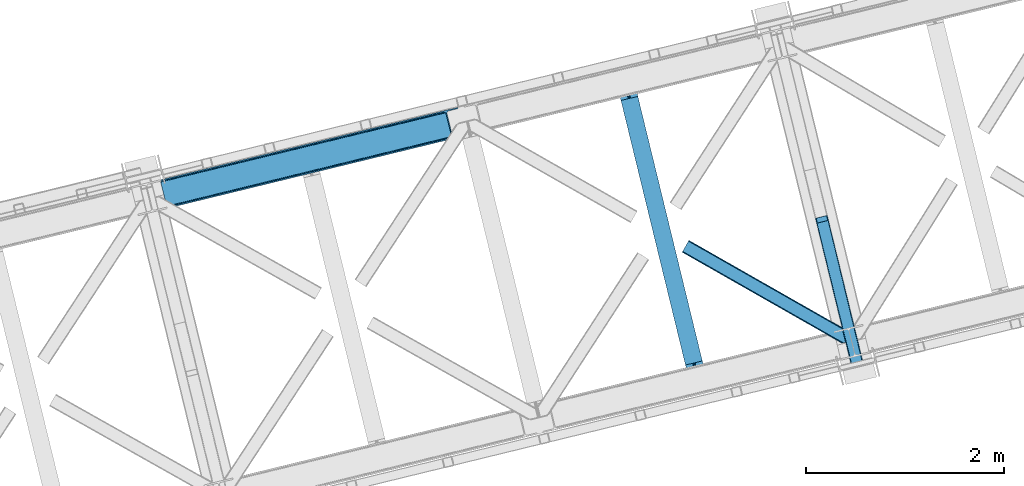
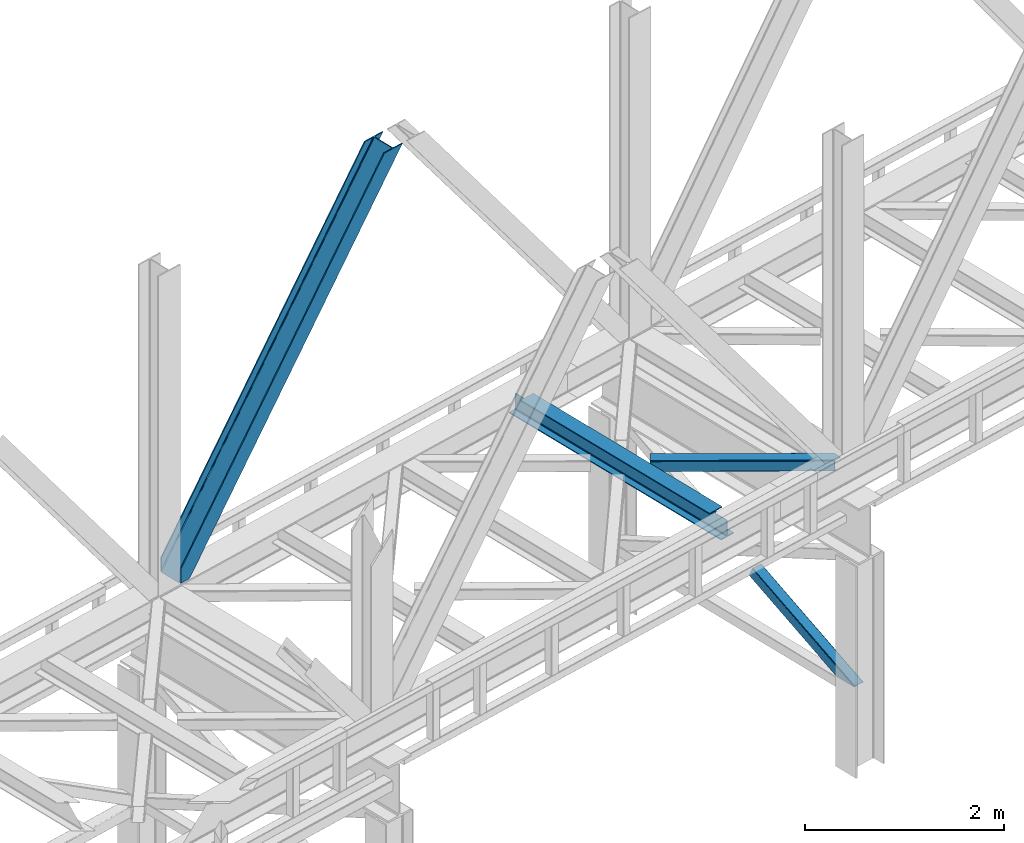
# One storey, part 55 of 92: 3 members, 1 beam.
"""IFC4 building model written with IfcOpenShell, lengths in millimetres."""

from ifc_helpers import new_model, entity, si_unit, converted_unit, derived_unit, direction, frame, origin, place, context, subcontext, project, spatial, triangles, polygons, material, type_object, element, save


model = new_model("IFC4")

# Units and contexts
model_context = context("Model", 3, precision=0.01, world=origin(), true_north=direction((6.12303176911189e-17, 1.0)))
plan_context = context("Plan", 3, precision=0.01, world=origin(), true_north=direction((6.12303176911189e-17, 1.0)))
body_context = subcontext(model_context, "Body", "Model", "MODEL_VIEW")
ifc_project = project(units=[si_unit("LENGTHUNIT", "METRE", prefix="MILLI"), si_unit("AREAUNIT", "SQUARE_METRE"), si_unit("VOLUMEUNIT", "CUBIC_METRE"), converted_unit("PLANEANGLEUNIT", "DEGREE", entity("IfcRatioMeasure", 0.0174532925199433), si_unit("PLANEANGLEUNIT", "RADIAN"), dimensions=[0, 0, 0, 0, 0, 0, 0]), si_unit("MASSUNIT", "GRAM", prefix="KILO"), derived_unit("MASSDENSITYUNIT", [(si_unit("MASSUNIT", "GRAM", prefix="KILO"), 1), (si_unit("LENGTHUNIT", "METRE"), -3)]), derived_unit("MOMENTOFINERTIAUNIT", [(si_unit("LENGTHUNIT", "METRE"), 4)]), si_unit("TIMEUNIT", "SECOND"), si_unit("FREQUENCYUNIT", "HERTZ"), si_unit("THERMODYNAMICTEMPERATUREUNIT", "DEGREE_CELSIUS"), derived_unit("THERMALTRANSMITTANCEUNIT", [(si_unit("MASSUNIT", "GRAM", prefix="KILO"), 1), (si_unit("THERMODYNAMICTEMPERATUREUNIT", "KELVIN"), -1), (si_unit("TIMEUNIT", "SECOND"), -3)]), derived_unit("VOLUMETRICFLOWRATEUNIT", [(si_unit("LENGTHUNIT", "METRE"), 3), (si_unit("TIMEUNIT", "SECOND"), -1)]), derived_unit("MASSFLOWRATEUNIT", [(si_unit("MASSUNIT", "GRAM", prefix="KILO"), 1), (si_unit("TIMEUNIT", "SECOND"), -1)]), derived_unit("ROTATIONALFREQUENCYUNIT", [(si_unit("TIMEUNIT", "SECOND"), -1)]), si_unit("ELECTRICCURRENTUNIT", "AMPERE"), si_unit("ELECTRICVOLTAGEUNIT", "VOLT"), si_unit("POWERUNIT", "WATT"), si_unit("FORCEUNIT", "NEWTON", prefix="KILO"), si_unit("ILLUMINANCEUNIT", "LUX"), si_unit("LUMINOUSFLUXUNIT", "LUMEN"), si_unit("LUMINOUSINTENSITYUNIT", "CANDELA"), derived_unit("USERDEFINED", [(si_unit("MASSUNIT", "GRAM", prefix="KILO"), -1), (si_unit("LENGTHUNIT", "METRE"), -2), (si_unit("TIMEUNIT", "SECOND"), 3), (si_unit("LUMINOUSFLUXUNIT", "LUMEN"), 1)]), derived_unit("LINEARVELOCITYUNIT", [(si_unit("LENGTHUNIT", "METRE"), 1), (si_unit("TIMEUNIT", "SECOND"), -1)]), si_unit("PRESSUREUNIT", "PASCAL"), derived_unit("USERDEFINED", [(si_unit("LENGTHUNIT", "METRE"), -2), (si_unit("MASSUNIT", "GRAM", prefix="KILO"), 1), (si_unit("TIMEUNIT", "SECOND"), -2)]), derived_unit("LINEARFORCEUNIT", [(si_unit("MASSUNIT", "GRAM", prefix="KILO"), 1), (si_unit("LENGTHUNIT", "METRE"), 1), (si_unit("TIMEUNIT", "SECOND"), -2), (si_unit("LENGTHUNIT", "METRE"), -1)]), derived_unit("PLANARFORCEUNIT", [(si_unit("MASSUNIT", "GRAM", prefix="KILO"), 1), (si_unit("LENGTHUNIT", "METRE"), 1), (si_unit("TIMEUNIT", "SECOND"), -2), (si_unit("LENGTHUNIT", "METRE"), -2)])], contexts=[model_context, plan_context])

# Site, building, storey
site_placement = place(None, origin())
site = spatial("IfcSite", under=ifc_project, at=site_placement, CompositionType="ELEMENT")
building_placement = place(site_placement, origin())
building = spatial("IfcBuilding", under=site, at=building_placement, CompositionType="ELEMENT")
storey_placement = place(building_placement, frame((0.0, 0.0, 15900.0)))
storey = spatial("IfcBuildingStorey", under=building, at=storey_placement, Name="05", CompositionType="ELEMENT", Elevation=15900.0)

# Beam
ifc_material = material(Name="Metal painted (White)")
beam_type = type_object("IfcBeamType", PredefinedType="BEAM")
beam_placement = place(storey_placement, frame((-31800.92, 10034.89, 3441.0)))
element("IfcBeam", 1, at=beam_placement, inside=storey, type_object=beam_type, material=ifc_material, ObjectType="Steel Beam", PredefinedType="BEAM", context=body_context, shape_type="Tessellation", body=[
    polygons([(900.98534618944, 41.4445662733081, 11.000000000004), (900.98534618944, 41.4445662733081, 2.16573425859679e-12), (170.021610174761, 3040.13999372697, 2.16573425859679e-12), (170.021610174761, 3040.13999372697, 11.000000000004), (834.919806235814, 25.3403919499634, 11.000000000004), (103.956070221139, 3024.03581940362, 11.000000000004), (828.971056214522, 23.8903211957374, 12.2179274798217), (98.007320199847, 3022.5857486494, 12.2179274798217), (823.927949458418, 22.6610105689194, 15.6862915010192), (92.9642134437384, 3021.35643802258, 15.6862915010192), (820.558253255246, 21.8396114687119, 20.8770650821657), (89.5945172405668, 3020.53503892237, 20.8770650821657), (819.374973305552, 21.5511744621184, 27.0000000000047), (88.4112372908766, 3020.24660191578, 27.0000000000047), (81.6103728838888, 3018.58881926485, 27.0000000000047), (81.6103728838844, 3018.58881926485, 203.000000000006), (88.4112372908766, 3020.24660191578, 203.000000000006), (0.0, 2998.69542745366, 2.16573425859679e-12), (4.33146851719357e-12, 2998.69542745366, 10.9999999999997), (66.0655399536259, 3014.799601777, 11.000000000004), (72.0142899749184, 3016.24967253123, 12.2179274798217), (77.0573967310183, 3017.47898315805, 15.6862915010192), (80.4270929342029, 3018.30038225825, 20.8770650821613), (819.374973305556, 21.5511744621184, 203.000000000006), (812.574108898559, 19.8933918111876, 203.000000000006), (812.574108898568, 19.8933918111876, 27.0000000000047), (811.390828948882, 19.6049548045963, 20.8770650821613), (808.021132745698, 18.7835557043866, 15.6862915010192), (802.978025989598, 17.5542450775685, 12.2179274798217), (797.029275968305, 16.1041743233403, 11.000000000004), (730.963736014684, -2.16573425859679e-12, 10.9999999999997), (730.963736014679, -2.16573425859679e-12, 2.16573425859679e-12), (779.675212882766, 184.415062601692, 203.069791966819), (128.020401343517, 2857.75452019162, 203.000000000006), (128.243282132667, 2856.84017775719, 203.617301946336), (128.25619637719, 2856.7871977843, 217.000003693143), (779.530009633841, 185.010597404072, 217.000003676718), (779.530880241731, 185.007025963192, 204.00000679514), (772.96491171832, 182.385463974439, 203.006342981529), (772.742064056778, 183.299815969774, 203.617301946336), (772.729149812254, 183.352795942665, 217.000003693143), (121.455336555608, 2855.12939632289, 217.000003676718), (121.45446594771, 2855.13296776377, 204.00000679514), (121.31016635866, 2855.72494066435, 203.076120467494), (121.219536936524, 2856.09673754069, 203.000000000006), (780.713494357868, 185.298194377514, 223.122939328039), (784.082490766543, 186.122464201391, 228.313710402595), (789.125126170563, 187.353708426697, 231.782072735464), (795.073705041266, 188.804481281379, 232.999999602236), (861.13915590679, 204.909021065313, 232.999999283132), (861.137682570352, 204.915065042186, 243.999994005812), (691.116301666435, 163.469558245295, 243.999994827032), (691.117775002873, 163.463514268422, 233.000000104353), (757.183225868396, 179.568054052358, 232.999999785253), (763.132130996735, 181.017488520584, 231.782072861012), (768.175695503857, 182.244921343716, 228.313710479427), (771.546082413602, 183.063487001146, 223.12293937232), (120.271851831572, 2854.84179934945, 223.122939328039), (116.902855422893, 2854.01752952557, 228.313710402595), (111.860220018882, 2852.78628530027, 231.782072735464), (105.91164114817, 2851.33551244559, 232.999999602236), (39.8461902826462, 2835.23097266165, 232.999999283128), (39.8476636190837, 2835.22492868478, 243.999994005812), (209.869044523001, 2876.67043548167, 243.999994827032), (209.867571186563, 2876.67647945854, 233.000000104357), (143.802120321035, 2860.57193967461, 232.999999785253), (137.853215192714, 2859.12250520638, 231.782072861012), (132.809650685579, 2857.89507238325, 228.313710479427), (129.439263775843, 2857.07650672582, 223.12293937232)], [[[1, 2, 3, 4]], [[5, 1, 4, 6]], [[7, 5, 6, 8]], [[9, 7, 8, 10]], [[11, 9, 10, 12]], [[13, 11, 12, 14]], [[15, 16, 17, 14, 12, 10, 8, 6, 4, 3, 18, 19, 20, 21, 22, 23]], [[13, 24, 25, 26, 27, 28, 29, 30, 31, 32, 2, 1, 5, 7, 9, 11]], [[2, 32, 18, 3]], [[32, 31, 19, 18]], [[31, 30, 20, 19]], [[27, 26, 15, 23]], [[28, 27, 23, 22]], [[29, 28, 22, 21]], [[30, 29, 21, 20]], [[33, 24, 13, 14, 17, 34, 35, 36, 37, 38]], [[25, 39, 40, 41, 42, 43, 44, 16, 15, 26]], [[39, 25, 24, 33]], [[45, 34, 17, 16]], [[41, 40, 38, 37, 46, 47, 48, 49, 50, 51, 52, 53, 54, 55, 56, 57]], [[42, 58, 59, 60, 61, 62, 63, 64, 65, 66, 67, 68, 69, 36, 35, 43]], [[46, 37, 36, 69]], [[47, 46, 69, 68]], [[48, 47, 68, 67]], [[49, 48, 67, 66]], [[50, 49, 66, 65]], [[51, 50, 65, 64]], [[52, 51, 64, 63]], [[53, 52, 63, 62]], [[54, 53, 62, 61]], [[55, 54, 61, 60]], [[56, 55, 60, 59]], [[57, 56, 59, 58]], [[41, 57, 58, 42]]], closed=False),
])

# Members
member_type_1 = type_object("IfcMemberType", PredefinedType="BRACE")
member_1_placement = place(storey_placement, frame((-36411.18, 11783.17, 3695.0)))
element("IfcMember", 2, at=member_1_placement, inside=storey, type_object=member_type_1, ObjectType="Steel Vertical Brace", PredefinedType="BRACE", context=body_context, shape_type="Tessellation", body=[
    triangles([(58.5289855957017, 27.9227142333984, 0.0), (60.4544494628863, 20.0173828124989, 0.0), (59.0963928222627, 20.9719757080074, 0.827856445310317), (58.9708190917954, 19.7941406249993, 1.13481445312209), (72.0351379394488, 11.6585906982418, 0.0), (71.2235595703096, 13.9003143310547, 30.2981506347642), (70.0794433593765, 15.4013854980458, 25.0194030761704), (72.0351379394488, 11.6585906982418, 170.803527832031), (71.7537597656265, 12.6201599121086, 41.9881347656228), (71.7537597656265, 12.6201599121086, 170.743066406249), (70.2445495605425, 15.5234710693348, 0.0), (68.6423217773408, 17.2884796142571, 18.377947998044), (66.9517272949233, 18.0907562255852, 14.9735046386704), (67.1168334960894, 18.4186431884755, 0.0), (63.12870483398, 19.9092498779282, 7.26932373046657), (63.12870483398, 19.9092498779282, 0.0), (2824.67177124023, 683.673385620117, 3911.00081176758), (2919.44040527344, 706.773138427734, 3911.00081176758), (2937.07653808594, 722.50938720703, 3911.00081176758), (2933.70465087891, 715.67724609375, 3911.00081176758), (2937.11839599609, 729.608953857422, 3911.00081176758), (2927.51200561523, 710.150839233398, 3911.00081176758), (2827.75065307617, 671.042761230468, 3911.00081176758), (74.8768249511704, 0.0, 170.803527832031), (74.8768249511704, 0.0, 0.0), (192.937060546872, 28.7784759521473, 0.0), (3071.52647094726, 730.46471557617, 3911.00081176758), (3068.44758911133, 743.095339965819, 3911.00081176758), (189.858178710936, 41.4091003417961, 0.0), (2973.67895507813, 719.994424438475, 3911.00081176758), (95.0918701171831, 18.308184814452, 0.0), (2964.95855712891, 719.279351806639, 3911.00081176758), (86.3691467285171, 17.5931121826161, 0.0), (2956.9171875, 721.336203002929, 3911.00081176758), (78.3277770996065, 19.648800659179, 0.0), (2950.77802734375, 725.848718261717, 3911.00081176758), (72.190942382811, 24.1624786376942, 0.0), (2947.47590332031, 732.134381103515, 3911.00081176758), (68.8888183593735, 30.4481414794918, 0.0), (2892.29555053711, 958.506610107421, 3911.00081176758), (13.7084655761719, 256.820370483398, 0.0), (2892.33508300781, 965.606176757812, 3911.00081176758), (13.7456726074233, 263.919937133789, 0.0), (2895.7092956543, 972.438317871092, 3911.00081176758), (17.1198852539019, 270.752078247069, 0.0), (2901.90194091797, 977.964724731444, 3911.00081176758), (23.3125305175781, 276.277322387694, 0.0), (2909.97354125977, 981.342425537108, 3911.00081176758), (31.3864562988238, 279.656185913085, 0.0), (3004.73984985351, 1004.44334106445, 3911.00081176758), (126.150439453122, 302.755938720702, 0.0), (3001.66096801758, 1017.07280273437, 3911.00081176758), (123.071557617186, 315.386563110351, 0.0), (2881.93804321289, 955.981182861327, 3911.00081176758), (3.34630737304542, 254.294943237304, 0.0), (2872.49443359375, 966.78052368164, 3911.00081176758), (2864.45306396484, 968.836212158203, 3911.00081176758), (2757.88747558594, 957.650848388672, 3911.00081176758), (2855.73499145508, 968.121139526367, 3911.00081176758), (2760.96635742187, 945.020223999023, 3911.00081176758), (2878.63359375, 962.265682983398, 3911.00081176758), (5.01364746093896, 286.608087158202, 170.803527832031), (5.01364746093896, 286.608087158202, 0.0), (7.85533447265334, 274.94949645996, 170.803527832031), (8.0460205078125, 273.966998291015, 170.743066406249), (8.0460205078125, 273.966998291015, 41.9881347656228), (7.85533447265334, 274.94949645996, 0.0), (3.74395751953125, 263.525775146483, 0.0), (6.59959716796584, 266.686047363281, 0.0), (8.04369506835792, 270.693942260741, 0.0), (1.42084350586083, 262.199111938477, 0.0), (3.74395751953125, 263.525775146483, 7.26932373046657), (6.30194091796875, 266.898825073242, 14.9735046386704), (7.43442993163626, 268.391757202147, 18.377947998044), (8.16694335937063, 272.585687255858, 30.2981506347642), (7.84138183593313, 270.727661132813, 25.0194030761704), (0.0, 261.715420532226, 1.13481445312209), (0.65344848632958, 260.728271484375, 0.827856445310317)], [[1, 2, 3], [4, 3, 2], [5, 6, 7], [5, 8, 9], [10, 9, 8], [9, 6, 5], [11, 12, 13], [11, 7, 12], [14, 13, 15], [15, 4, 2], [2, 16, 15], [15, 16, 14], [13, 14, 11], [7, 11, 5], [17, 18, 10], [9, 10, 18], [19, 3, 15], [15, 20, 19], [12, 20, 13], [15, 13, 20], [3, 4, 15], [19, 21, 1], [1, 3, 19], [6, 20, 7], [6, 22, 20], [12, 7, 20], [18, 22, 9], [6, 9, 22], [8, 17, 10], [23, 8, 24], [8, 23, 17], [25, 24, 5], [8, 5, 24], [23, 26, 27], [26, 23, 24], [25, 26, 24], [28, 27, 29], [26, 29, 27], [30, 28, 29], [29, 31, 30], [32, 30, 31], [31, 33, 32], [34, 32, 33], [33, 35, 34], [36, 34, 35], [35, 37, 36], [38, 36, 37], [37, 39, 38], [40, 38, 39], [39, 41, 40], [42, 40, 43], [41, 43, 40], [44, 42, 45], [43, 45, 42], [46, 44, 47], [45, 47, 44], [48, 46, 49], [47, 49, 46], [50, 48, 51], [49, 51, 48], [52, 50, 53], [51, 53, 50], [21, 54, 1], [55, 1, 54], [54, 21, 40], [20, 22, 32], [18, 23, 27], [17, 23, 18], [22, 18, 30], [21, 19, 36], [19, 20, 34], [56, 46, 57], [58, 59, 52], [59, 57, 48], [58, 60, 59], [56, 61, 44], [61, 54, 42], [40, 21, 38], [30, 32, 22], [36, 19, 34], [32, 34, 20], [36, 38, 21], [27, 30, 18], [27, 28, 30], [48, 57, 46], [44, 61, 42], [40, 42, 54], [44, 46, 56], [48, 52, 59], [52, 48, 50], [58, 53, 62], [58, 52, 53], [53, 63, 62], [64, 58, 62], [60, 64, 65], [64, 60, 58], [59, 60, 65], [65, 66, 59], [67, 64, 62], [62, 63, 67], [11, 35, 5], [68, 41, 55], [69, 70, 43], [69, 43, 68], [55, 71, 68], [67, 63, 47], [67, 45, 70], [55, 39, 1], [37, 14, 16], [2, 1, 16], [16, 1, 39], [11, 14, 37], [25, 5, 33], [39, 55, 41], [49, 47, 63], [43, 70, 45], [47, 45, 67], [43, 41, 68], [53, 49, 63], [53, 51, 49], [31, 25, 33], [35, 11, 37], [39, 37, 16], [35, 33, 5], [31, 26, 25], [26, 31, 29], [72, 68, 71], [69, 68, 72], [70, 69, 73], [73, 74, 70], [67, 75, 66], [67, 70, 76], [76, 75, 67], [64, 67, 66], [66, 65, 64], [74, 76, 70], [72, 73, 69], [71, 77, 72], [78, 61, 72], [61, 56, 74], [74, 73, 61], [73, 72, 61], [57, 59, 66], [66, 75, 57], [56, 75, 76], [75, 56, 57], [76, 74, 56], [72, 77, 78], [54, 61, 55], [78, 55, 61], [71, 55, 78], [78, 77, 71]]),
])
member_type_2 = type_object("IfcMemberType", PredefinedType="BRACE")
member_2_placement = place(storey_placement, frame((-29797.84, 10185.59, 970.5)))
element("IfcMember", 3, at=member_2_placement, inside=storey, type_object=member_type_2, ObjectType="Steel Vertical Brace", PredefinedType="BRACE", context=body_context, shape_type="Tessellation", body=[
    polygons([(310.156875969819, 236.659699185643, 1.04388391264365e-09), (309.042346364983, 243.803283956979, 1.04171817838505e-09), (4.57230123624037, 1492.85694714149, 603.530503671959), (4.28876445601824, 1491.44877039324, 606.301796687595), (309.28077373894, 250.147759710235, 1.04171817838505e-09), (5.99595206163126, 1494.33917875157, 601.181114896122), (310.835859685349, 254.727237524781, 1.05038111541944e-09), (8.34297899943964, 1495.6698088973, 599.611303503951), (313.470856465754, 256.844533416439, 1.04171817838505e-09), (11.2560684742533, 1496.64626120118, 599.060059049496), (366.444630080976, 5.74560241384962, 1.00706643024751e-09), (14.4533090982474, 1449.74988433501, 697.72873436856), (411.597614338037, 280.763968808463, 1.04171817838505e-09), (109.38282634654, 1520.5656965932, 599.060059049498), (425.485457020336, 274.46076918091, 1.03522097560926e-09), (485.1720650288, 29.6032616237767, 9.24768528420827e-10), (481.013627176896, 28.589598401482, 9.24768528420827e-10), (480.11622088353, 33.4542552937189, 9.72414682109957e-10), (423.828466772369, 264.36835206551, 1.03305524135067e-09), (421.530657217855, 271.223499830257, 1.03522097560926e-09), (418.399388388632, 276.746576483303, 1.03738670986786e-09), (414.911367578928, 280.096743671033, 1.04171817838505e-09), (367.886495613074, 1.01366322182258, 9.29099996938021e-10), (363.72805776111, 2.16573425859679e-12, 5.76085312786745e-10), (304.041449752647, 244.857507557116, 1.03522097560926e-09), (302.926920147819, 252.001092328463, 1.04171817838505e-09), (303.165347521772, 258.345568081722, 1.03738670986786e-09), (304.720433468181, 262.925045896265, 1.04604964690225e-09), (307.355430248582, 265.042341787917, 1.04388391264365e-09), (413.254604586004, 290.856385923862, 1.04604964690225e-09), (416.568357826896, 290.18916078644, 1.04604964690225e-09), (420.056378636591, 286.83899359871, 1.04171817838505e-09), (423.187647465818, 281.315916945664, 1.04171817838505e-09), (112.418486893027, 1521.03931504355, 599.611303503942), (115.114566711319, 1520.93799552464, 601.181114896124), (117.060612089113, 1520.27716301478, 603.530503671961), (117.960355258576, 1519.15742327311, 606.301796687595), (128.124899900797, 1477.45853721488, 697.72873436856), (127.841363120579, 1476.05036046663, 700.50002738419), (126.417712295197, 1474.56812885656, 702.849416160034), (124.070685357388, 1473.23749871082, 704.419227552215), (121.157595882579, 1472.26104640694, 704.970472006657), (23.0308380102839, 1448.34161101491, 704.970472006657), (19.9951774638007, 1447.86799256457, 704.419227552218), (17.2990976455048, 1447.96931208348, 702.849416160034), (15.3530522677154, 1448.63014459335, 700.500027384193), (112.866478355649, 1523.16444199718, 595.439190230451), (6.9673040182264, 1497.35039786123, 595.439190230448), (4.05421454341274, 1496.37394555734, 595.990434684895), (1.70718760560436, 1495.04331541162, 597.56024607707), (0.283536780226461, 1493.56108380154, 599.909634852913), (4.33146851719357e-12, 1492.15290705329, 602.680927868548), (10.9696570891342, 1447.15113893104, 701.349603187608), (11.8694002586022, 1446.03139918938, 704.120896203242), (13.8154456363959, 1445.37056667951, 706.470284979081), (16.5115254546918, 1445.2692471606, 708.040096371263), (19.547186001175, 1445.74286561094, 708.591340825705), (125.446360338597, 1471.55690974689, 708.591340825705), (128.359449813407, 1472.53336205077, 708.040096371265), (130.706476751211, 1473.8639921965, 706.470284979081), (132.130127576602, 1475.34622380658, 704.120896203244), (132.413664356819, 1476.75440055483, 701.349603187608), (121.444007267694, 1521.75616867708, 602.680927868548), (120.54426409823, 1522.87590841874, 599.909634852913), (118.598218720423, 1523.53674092861, 597.560246077077), (115.902138902132, 1523.63806044752, 595.990434684895), (375.386682458811, 2.84191311588703, 6.51916727653314), (372.638718264457, 2.17206777061844, 5.2249222388966), (369.890754070111, 1.50222242536501, 3.93067720123841), (368.373326648029, 1.13233343716383, 0.954754934343811), (480.407239661998, 28.441785029781, 0.783330976602792), (478.425418155212, 27.9586950702395, 3.34344663920135), (476.487815341744, 27.4863838850221, 5.84644062407408), (473.513440331098, 26.7613485079113, 6.51916727653314), (485.172065028804, 29.6032616237637, 2.10033831597304), (484.033820990588, 29.3258025970721, 5.22492223888794), (482.895576952369, 29.048343570374, 8.34950616180717), (480.147612758023, 28.3784982251097, 9.64375119945237), (477.399648563668, 27.7086528798498, 10.9379962370932), (371.500474226241, 1.89460874392469, 10.9379962370954), (368.752510031891, 1.22476339866259, 9.6437511994502), (366.004545837554, 0.554918053404833, 8.34950616180934), (364.866301799325, 0.277459026702417, 5.2249222388901), (363.72805776111, 4.33146851719357e-12, 2.10033831597304)], [[[1, 2, 3, 4]], [[2, 5, 6, 3]], [[5, 7, 8, 6]], [[7, 9, 10, 8]], [[11, 1, 4, 12]], [[9, 13, 14, 10]], [[15, 16, 17, 18, 19, 20, 21, 22, 13, 9, 7, 5, 2, 1, 11, 23, 24, 25, 26, 27, 28, 29, 30, 31, 32, 33]], [[47, 48, 49, 50, 51, 52, 53, 54, 55, 56, 57, 58, 59, 60, 61, 62, 63, 64, 65, 66], [10, 14, 34, 35, 36, 37, 38, 39, 40, 41, 42, 43, 44, 45, 46, 12, 4, 3, 6, 8]], [[13, 22, 34, 14]], [[22, 21, 35, 34]], [[21, 20, 36, 35]], [[20, 19, 37, 36]], [[19, 18, 38, 37]], [[44, 67, 68]], [[45, 68, 69]], [[46, 69, 70]], [[46, 11, 12]], [[11, 70, 23]], [[11, 46, 70]], [[69, 46, 45]], [[68, 45, 44]], [[67, 44, 43]], [[71, 18, 17]], [[39, 72, 40]], [[40, 73, 41]], [[73, 74, 42, 41]], [[73, 40, 72]], [[72, 39, 71]], [[39, 18, 71]], [[18, 39, 38]], [[42, 74, 67, 43]], [[16, 75, 76, 77, 78, 79, 80, 81, 82, 83, 84, 24, 23, 70, 69, 68, 67, 74, 73, 72, 71, 17]], [[29, 28, 49, 48]], [[28, 27, 50, 49]], [[27, 26, 51, 50]], [[26, 25, 52, 51]], [[47, 30, 29, 48]], [[15, 33, 64, 63]], [[33, 32, 65, 64]], [[32, 31, 66, 65]], [[31, 30, 47, 66]], [[24, 84, 53, 52, 25]], [[75, 16, 15, 63, 62]], [[53, 83, 54]], [[54, 82, 55]], [[55, 81, 56]], [[56, 80, 57]], [[80, 56, 81]], [[81, 55, 82]], [[82, 54, 83]], [[83, 53, 84]], [[80, 79, 58, 57]], [[59, 79, 78]], [[60, 78, 77]], [[61, 77, 76]], [[62, 76, 75]], [[76, 62, 61]], [[77, 61, 60]], [[78, 60, 59]], [[79, 59, 58]]], closed=True),
])
member_type_3 = type_object("IfcMemberType", PredefinedType="BRACE")
member_3_placement = place(storey_placement, frame((-31143.99, 10419.12, 3510.06)))
element("IfcMember", 4, at=member_3_placement, inside=storey, type_object=member_type_3, ObjectType="Steel Horizontal Brace", PredefinedType="BRACE", context=body_context, shape_type="Tessellation", body=[
    triangles([(1627.55879516602, 3.72651672363281, 138.64386291504), (1637.03728637695, 6.03684082031214, 139.974014282227), (8.68319091796729, 933.153506469725, 140.385617065429), (5.36711425781323, 927.332931518555, 139.053140258788), (1619.52672729492, 1.767333984375, 134.851071166991), (2.5579833984375, 922.39951171875, 135.260348510743), (1614.15728759766, 0.459274291992188, 129.174673461916), (0.681353759766353, 919.104364013672, 129.581625366212), (1612.27135620117, 0.0, 122.477407836916), (0.0209289550766698, 917.947457885743, 122.884359741212), (1612.27135620117, 0.0, 17.478002929689), (0.0, 917.957922363281, 17.8849548339858), (1676.30930786133, 104.50408630371, 139.978665161132), (1696.76387329102, 20.5952545166019, 139.964712524416), (60.6335083007798, 1024.39909973144, 140.385617065429), (1671.04451293945, 126.106256103516, 129.176998901366), (1670.60965576172, 127.886380004882, 122.482058715821), (68.6330200195298, 1038.45173034668, 129.581625366212), (69.2911193847649, 1039.60979919434, 122.884359741212), (1672.27932128906, 121.037960815429, 134.853396606446), (66.7540649414077, 1035.15425720215, 135.260348510743), (1674.13037109375, 113.452377319336, 138.646188354491), (63.9472595214829, 1030.21967468262, 139.053140258788), (1670.60965576172, 127.886380004882, 17.4814910888672), (69.2678649902336, 1039.62026367188, 17.8849548339858), (0.658099365235103, 919.117153930663, 11.1876892089858), (1614.54563598633, 0.554617309569949, 10.8481750488281), (1543.47090454102, 41.4207275390618, 9.46221313476417), (2.53240356445167, 922.413464355468, 5.51129150390625), (1541.24313354492, 46.3401947021484, 5.1229431152351), (1542.09424438477, 42.8473846435536, 8.46227416992042), (1543.13836669922, 41.764892578125, 9.22036743164063), (1542.78257446289, 42.1334747314449, 8.96224365234229), (1542.42678222656, 42.5032196044922, 8.7041198730476), (1615.02235107422, 0.669726562498909, 9.46221313476417), (1539.39208374023, 53.9257781982415, 1.33015136718677), (5.3415344238274, 927.348046875, 1.71733703613427), (1537.2108215332, 62.8740692138672, 0.0), (8.65528564453052, 933.168621826171, 0.384860229492915), (1503.01290893555, 203.171319580078, 0.0209289550766698), (60.6079284667976, 1024.41537780762, 0.384860229492915), (1634.21885375976, 5.34967346191297, 9.46221313476417), (1539.04326782226, 59.5847351074208, 9.46221313476417), (1538.54329833984, 60.0172668457035, 9.38547363281396), (1538.10146484375, 60.9648834228519, 9.07851562499854), (1537.65498046875, 61.9218017578114, 8.76923217773583), (1537.21314697266, 62.8694183349598, 8.46227416992042), (8.80643920898365, 933.430233764648, 8.71690979004052), (1537.10850219726, 63.299624633788, 8.39483642578125), (5.99730834960792, 928.496813964843, 12.5108642578125), (1629.43309936523, 4.18230285644495, 12.101586914061), (1534.93189086914, 72.2269866943352, 7.00073547363354), (12.1201904296868, 939.25080871582, 7.38559570312646), (1624.06365966797, 2.87424316406214, 17.7791473388679), (4.12300415039135, 925.199340820313, 18.1884246826157), (1622.17772827148, 2.41496887206995, 24.4764129638679), (3.46490478515625, 924.041271972656, 24.8845275878921), (1622.17772827148, 2.41496887206995, 115.477835083009), (3.4811828613274, 924.030807495117, 115.884786987306), (1629.43309936523, 4.18230285644495, 127.849172973634), (1637.46749267578, 6.14148559570276, 131.641964721679), (1624.06365966797, 2.87424316406214, 122.172775268555), (1646.94365844726, 8.45180969238208, 132.972116088866), (1696.76387329102, 20.5952545166019, 132.965139770509), (4.14393310546802, 925.187713623047, 122.582052612306), (6.02056274413917, 928.484024047852, 128.258450317382), (8.8296936035149, 933.417443847657, 132.053567504881), (12.1457702636726, 939.236856079102, 133.386044311523), (1678.59056396484, 95.1500061035149, 132.976766967775), (57.1686035156235, 1018.3169128418, 133.386044311523), (1505.29183959961, 193.818402099609, 7.01933898925927), (57.1453491210923, 1018.33086547852, 7.38559570312646), (68.6097656249985, 1038.46452026367, 11.1876892089858), (63.2682312011711, 1029.08369750976, 12.5108642578125), (65.1471862792969, 1032.38000793457, 18.1884246826157), (65.8076110839829, 1033.5369140625, 24.8845275878921), (66.7308105468765, 1035.16820983887, 5.51129150390625), (63.9216796875007, 1030.23479003906, 1.71733703613427), (60.4591003417954, 1024.15027770996, 8.71690979004052), (63.2914855957024, 1029.07090759277, 128.258450317382), (65.8262145996086, 1033.52761230469, 115.884786987306), (65.1681152343735, 1032.36954345703, 122.582052612306), (60.4823547363267, 1024.13748779297, 132.053567504881), (1672.89091186523, 118.533462524414, 24.4799011230461), (1672.89091186523, 118.533462524414, 115.48016052246), (1676.40930175781, 104.098297119141, 131.644290161134), (1674.56057739258, 111.685043334961, 127.85382385254), (1673.32344360352, 116.753338623046, 122.17742614746), (1674.56057739258, 111.685043334961, 12.1039123535156), (1675.66283569336, 107.15973815918, 9.46221313476417), (1671.24450073242, 125.287701416015, 9.46221313476417), (1673.32344360352, 116.753338623046, 17.7826354980461), (1671.13520507812, 125.737673950194, 10.8516632080064), (1498.13646240234, 223.174749755859, 8.46227416992042), (1503.02686157227, 203.10969543457, 8.46227416992042), (1498.98292236328, 219.705194091797, 5.14968566894458), (1503.11522827148, 202.749252319336, 8.40646362304688), (1500.83164672851, 212.119610595702, 1.35456848144531), (1498.15274047852, 223.423571777343, 8.84480895996239), (1499.14802856445, 223.244512939453, 9.46221313476417), (1498.47830200195, 223.365435791015, 9.04595947265625), (1503.58496704102, 205.049111938477, 9.46221313476417), (1502.96640014648, 203.975921630859, 8.81574096679833)], [[1, 2, 3], [3, 4, 1], [5, 1, 4], [4, 6, 5], [7, 5, 6], [6, 8, 7], [9, 7, 8], [8, 10, 9], [11, 9, 12], [10, 12, 9], [2, 13, 3], [2, 14, 13], [15, 3, 13], [16, 17, 18], [19, 18, 17], [20, 16, 21], [18, 21, 16], [22, 20, 23], [21, 23, 20], [13, 22, 15], [23, 15, 22], [17, 24, 25], [25, 19, 17], [26, 27, 11], [27, 26, 28], [26, 29, 30], [30, 31, 26], [32, 26, 33], [32, 28, 26], [26, 34, 33], [26, 31, 34], [28, 35, 27], [36, 30, 29], [29, 37, 36], [38, 36, 37], [37, 39, 38], [11, 12, 26], [40, 38, 39], [39, 41, 40], [42, 35, 43], [28, 43, 35], [32, 44, 43], [33, 45, 44], [34, 46, 45], [31, 47, 46], [46, 34, 31], [45, 33, 34], [44, 32, 33], [43, 28, 32], [45, 48, 44], [48, 45, 46], [47, 48, 46], [47, 49, 48], [50, 51, 43], [43, 48, 50], [43, 44, 48], [51, 42, 43], [48, 49, 52], [52, 53, 48], [54, 51, 50], [50, 55, 54], [56, 54, 55], [55, 57, 56], [58, 56, 57], [57, 59, 58], [60, 61, 1], [5, 60, 1], [5, 7, 62], [60, 5, 62], [62, 7, 9], [61, 2, 1], [63, 2, 61], [14, 63, 64], [63, 14, 2], [62, 9, 58], [56, 11, 54], [11, 58, 9], [11, 27, 54], [11, 56, 58], [35, 54, 27], [51, 54, 35], [42, 51, 35], [62, 58, 65], [59, 65, 58], [60, 62, 66], [65, 66, 62], [61, 60, 67], [66, 67, 60], [63, 61, 68], [67, 68, 61], [69, 63, 68], [63, 69, 64], [68, 70, 69], [52, 71, 53], [72, 53, 71], [73, 74, 75], [76, 19, 25], [73, 75, 25], [73, 77, 74], [75, 76, 25], [74, 77, 78], [72, 41, 39], [41, 79, 78], [79, 41, 72], [79, 74, 78], [18, 80, 21], [81, 19, 76], [19, 82, 18], [82, 19, 81], [18, 82, 80], [15, 70, 3], [23, 21, 80], [80, 83, 23], [83, 70, 15], [15, 23, 83], [50, 37, 29], [39, 53, 72], [39, 48, 53], [48, 39, 37], [50, 48, 37], [57, 12, 10], [26, 55, 50], [29, 26, 50], [55, 26, 12], [57, 55, 12], [4, 66, 6], [3, 70, 68], [68, 67, 3], [67, 66, 4], [4, 3, 67], [8, 6, 66], [10, 59, 57], [65, 10, 8], [10, 65, 59], [65, 8, 66], [84, 85, 76], [81, 76, 85], [86, 69, 70], [70, 83, 86], [87, 86, 83], [83, 80, 87], [88, 87, 80], [80, 82, 88], [85, 88, 82], [82, 81, 85], [87, 20, 22], [89, 90, 91], [20, 87, 88], [86, 87, 22], [86, 13, 69], [14, 69, 13], [69, 14, 64], [86, 22, 13], [24, 85, 84], [91, 92, 89], [92, 24, 84], [93, 92, 91], [93, 24, 92], [17, 85, 24], [88, 16, 20], [17, 16, 88], [85, 17, 88], [40, 71, 52], [94, 95, 96], [95, 97, 40], [71, 40, 97], [95, 98, 96], [95, 40, 98], [38, 40, 52], [38, 52, 49], [47, 38, 49], [31, 30, 47], [47, 36, 38], [47, 30, 36], [73, 25, 24], [77, 99, 94], [73, 93, 100], [100, 77, 73], [100, 101, 77], [93, 91, 100], [94, 96, 77], [98, 40, 41], [41, 78, 98], [96, 98, 78], [78, 77, 96], [24, 93, 73], [72, 71, 95], [102, 89, 74], [102, 90, 89], [95, 74, 79], [103, 102, 74], [74, 95, 103], [95, 79, 72], [92, 84, 75], [76, 75, 84], [89, 92, 74], [75, 74, 92], [102, 103, 94], [103, 95, 94], [91, 90, 102], [102, 100, 91]]),
])

save(model, "model.ifc")
